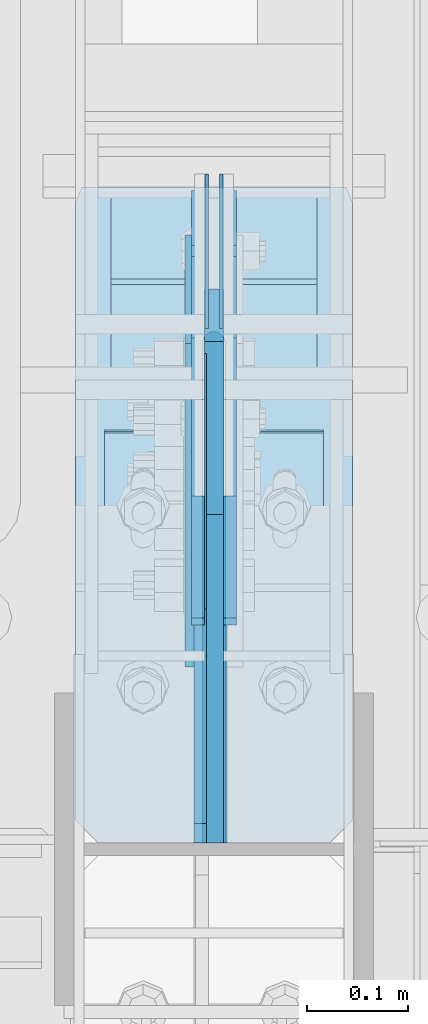
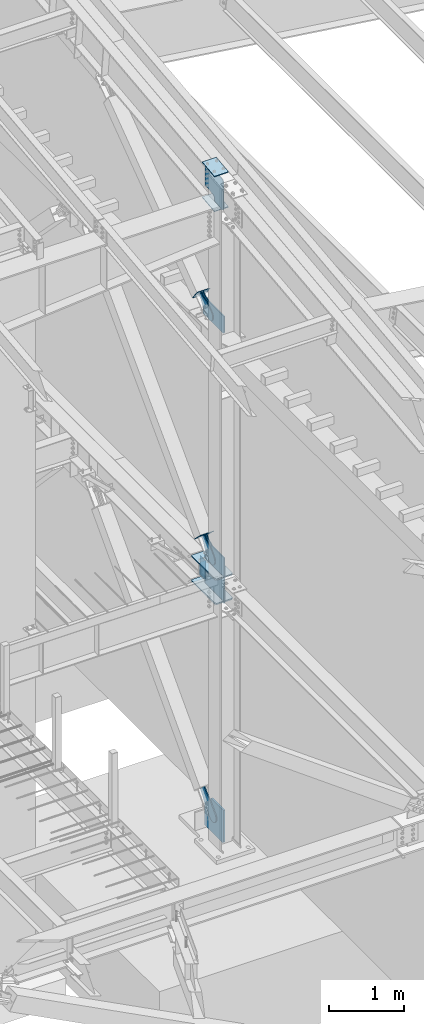
# One storey, part 1011 of 1179: 17 plates, 9 elements without a shape of their own.
"""IFC2X3 building model written with IfcOpenShell, lengths in millimetres."""

from ifc_helpers import new_model, si_unit, frame, origin_with_axes, place, context, subcontext, project, spatial, faceted_brep, material, type_object, element, aggregate, save


model = new_model("IFC2X3")

# Units and contexts
model_context = context("Model", 3, precision=1e-05, world=origin_with_axes())
body_context = subcontext(model_context, "Body", "Model", "MODEL_VIEW")
ifc_project = project(units=[si_unit("LENGTHUNIT", "METRE", prefix="MILLI"), si_unit("AREAUNIT", "SQUARE_METRE"), si_unit("VOLUMEUNIT", "CUBIC_METRE"), si_unit("MASSUNIT", "GRAM", prefix="KILO"), si_unit("TIMEUNIT", "SECOND"), si_unit("PLANEANGLEUNIT", "RADIAN"), si_unit("SOLIDANGLEUNIT", "STERADIAN"), si_unit("THERMODYNAMICTEMPERATUREUNIT", "DEGREE_CELSIUS"), si_unit("LUMINOUSINTENSITYUNIT", "LUMEN")], contexts=[model_context])

# Site, building, storey
site_placement = place(None, origin_with_axes())
site = spatial("IfcSite", under=ifc_project, at=site_placement, CompositionType="ELEMENT")
building_placement = place(site_placement, origin_with_axes())
building = spatial("IfcBuilding", under=site, at=building_placement, Name="Undefined", CompositionType="ELEMENT")
storey_placement = place(building_placement, origin_with_axes())
storey = spatial("IfcBuildingStorey", under=building, at=storey_placement, Name="Undefined", CompositionType="ELEMENT", Elevation=0.0)

# Assembly, plates
assembly_1_placement = place(storey_placement, origin_with_axes())
assembly_1 = element("IfcElementAssembly", 1, at=assembly_1_placement, inside=storey, Name="COLUMN", AssemblyPlace="NOTDEFINED", PredefinedType="RIGID_FRAME")
ifc_material_1 = material(Name="STEEL/A572-GR.50")
plate_type_1 = type_object("IfcPlateType", PredefinedType="NOTDEFINED")
plate_1_placement = place(assembly_1_placement, frame((24171.275012207, 12133.5984303229, 3694.1125), z_axis=(0.0, -1.0, 0.0), x_axis=(1.0, 0.0, 0.0)))
plate_1 = element("IfcPlate", 2, at=plate_1_placement, type_object=plate_type_1, material=ifc_material_1, Name="PLATE", context=body_context, shape_type="Brep", body=[
    faceted_brep([(125.412487792968, -11.1125000000002, 646.448430322878), (125.412487792968, -11.1125000000002, 153.987500190735), (125.412487792968, 11.1125000000002, 153.987500190735), (125.412487792968, 11.1125000000002, 646.448430322878), (126.258376502454, -11.1125000000002, 149.734930475586), (126.258376502454, 11.1125000000002, 149.734930475586), (128.667263742896, -11.1125000000002, 146.12977594993), (128.667263742896, 11.1125000000002, 146.12977594993), (132.272418268556, -11.1125000000002, 143.720888709488), (132.272418268556, 11.1125000000002, 143.720888709488), (136.524987602239, -11.1125000000002, 142.875), (136.524987602239, 11.1125000000002, 142.875), (140.777557317386, -11.1125000000002, 143.720888709488), (140.777557317386, 11.1125000000002, 143.720888709488), (144.382711843045, -11.1125000000002, 146.12977594993), (144.382711843045, 11.1125000000002, 146.12977594993), (146.791599083488, -11.1125000000002, 149.734930475586), (146.791599083488, 11.1125000000002, 149.734930475586), (147.637487792974, -11.1125000000002, 153.987500190735), (147.637487792974, 11.1125000000002, 153.987500190735), (147.637487792974, -11.1125000000002, 646.448430322878), (147.637487792974, 11.1125000000002, 646.448430322878), (0.0, -11.1125000000002, 624.223429941409), (22.2250003814697, -11.1125000000002, 646.448430322878), (22.2250003814697, 11.1125000000002, 646.448430322878), (0.0, 11.1125000000002, 624.223429941409), (0.0, -11.1125000000002, 15.875), (0.0, 11.1125000000002, 15.875), (6.34999990463257, -11.1125000000002, 0.0), (6.34999990463257, 11.1125000000002, 0.0), (266.699987888336, -11.1125000000002, 0.0), (266.699987888336, 11.1125000000002, 0.0), (273.049987792969, -11.1125000000002, 15.875), (273.049987792969, 11.1125000000002, 15.875), (273.049987792969, -11.1125000000002, 624.223429941409), (273.049987792969, 11.1125000000002, 624.223429941409), (250.824987411499, -11.1125000000002, 646.448430322878), (250.824987411499, 11.1125000000002, 646.448430322878)], [[[0, 1, 2, 3]], [[4, 5, 2, 1]], [[6, 7, 5, 4]], [[8, 9, 7, 6]], [[10, 11, 9, 8]], [[12, 13, 11, 10]], [[14, 15, 13, 12]], [[16, 17, 15, 14]], [[18, 19, 17, 16]], [[20, 21, 19, 18]], [[22, 23, 24, 25]], [[26, 22, 25, 27]], [[28, 26, 27, 29]], [[30, 28, 29, 31]], [[32, 30, 31, 33]], [[34, 32, 33, 35]], [[36, 34, 35, 37]], [[16, 14, 12, 10, 8, 6, 4, 1, 0, 23, 22, 26, 28, 30, 32, 34, 36, 20, 18]], [[24, 23, 0, 3]], [[37, 35, 33, 31, 29, 27, 25, 24, 3, 2, 5, 7, 9, 11, 13, 15, 17, 19, 21]], [[36, 37, 21, 20]]]),
])
plate_2_placement = place(assembly_1_placement, frame((24171.275012207, 12133.5984303229, 4090.9875), z_axis=(0.0, -1.0, 0.0), x_axis=(1.0, 0.0, 0.0)))
plate_2 = element("IfcPlate", 3, at=plate_2_placement, type_object=plate_type_1, material=ifc_material_1, Name="PLATE", context=body_context, shape_type="Brep", body=[
    faceted_brep([(125.412487792968, -11.1125000000002, 646.448430322878), (125.412487792968, -11.1125000000002, 153.987500190735), (125.412487792968, 11.1125000000002, 153.987500190735), (125.412487792968, 11.1125000000002, 646.448430322878), (126.258376502454, -11.1125000000002, 149.734930475586), (126.258376502454, 11.1125000000002, 149.734930475586), (128.667263742896, -11.1125000000002, 146.12977594993), (128.667263742896, 11.1125000000002, 146.12977594993), (132.272418268556, -11.1125000000002, 143.720888709488), (132.272418268556, 11.1125000000002, 143.720888709488), (136.524987602239, -11.1125000000002, 142.875), (136.524987602239, 11.1125000000002, 142.875), (140.777557317386, -11.1125000000002, 143.720888709488), (140.777557317386, 11.1125000000002, 143.720888709488), (144.382711843045, -11.1125000000002, 146.12977594993), (144.382711843045, 11.1125000000002, 146.12977594993), (146.791599083488, -11.1125000000002, 149.734930475586), (146.791599083488, 11.1125000000002, 149.734930475586), (147.637487792974, -11.1125000000002, 153.987500190735), (147.637487792974, 11.1125000000002, 153.987500190735), (147.637487792974, -11.1125000000002, 646.448430322878), (147.637487792974, 11.1125000000002, 646.448430322878), (0.0, -11.1125000000002, 624.223429941409), (22.2250003814697, -11.1125000000002, 646.448430322878), (22.2250003814697, 11.1125000000002, 646.448430322878), (0.0, 11.1125000000002, 624.223429941409), (0.0, -11.1125000000002, 15.875), (0.0, 11.1125000000002, 15.875), (6.34999990463257, -11.1125000000002, 0.0), (6.34999990463257, 11.1125000000002, 0.0), (266.699987888336, -11.1125000000002, 0.0), (266.699987888336, 11.1125000000002, 0.0), (273.049987792969, -11.1125000000002, 15.875), (273.049987792969, 11.1125000000002, 15.875), (273.049987792969, -11.1125000000002, 624.223429941409), (273.049987792969, 11.1125000000002, 624.223429941409), (250.824987411499, -11.1125000000002, 646.448430322878), (250.824987411499, 11.1125000000002, 646.448430322878)], [[[0, 1, 2, 3]], [[4, 5, 2, 1]], [[6, 7, 5, 4]], [[8, 9, 7, 6]], [[10, 11, 9, 8]], [[12, 13, 11, 10]], [[14, 15, 13, 12]], [[16, 17, 15, 14]], [[18, 19, 17, 16]], [[20, 21, 19, 18]], [[22, 23, 24, 25]], [[26, 22, 25, 27]], [[28, 26, 27, 29]], [[30, 28, 29, 31]], [[32, 30, 31, 33]], [[34, 32, 33, 35]], [[36, 34, 35, 37]], [[16, 14, 12, 10, 8, 6, 4, 1, 0, 23, 22, 26, 28, 30, 32, 34, 36, 20, 18]], [[24, 23, 0, 3]], [[37, 35, 33, 31, 29, 27, 25, 24, 3, 2, 5, 7, 9, 11, 13, 15, 17, 19, 21]], [[36, 37, 21, 20]]]),
])

# Assembly, plate
assembly_2_placement = place(storey_placement, origin_with_axes())
assembly_2 = element("IfcElementAssembly", 4, at=assembly_2_placement, inside=storey, AssemblyPlace="NOTDEFINED", PredefinedType="RIGID_FRAME")
ifc_material_2 = material(Name="STEEL/A36")
plate_type_2 = type_object("IfcPlateType", PredefinedType="NOTDEFINED")
plate_3_placement = place(assembly_2_placement, frame((24291.925, 12073.4864281147, 8239.6757127596), z_axis=(0.0, -0.591857899923163, 0.806042322895357), x_axis=(0.0, 0.806042322895357, 0.591857899923163)))
plate_3 = element("IfcPlate", 5, at=plate_3_placement, type_object=plate_type_2, material=ifc_material_2, context=body_context, shape_type="Brep", body=[
    faceted_brep([(0.0, -6.34999999999854, 0.0), (-101.600000000211, -6.34999999999854, -44.6881937825565), (-101.600000000211, 6.34999999999854, -44.6881937825565), (0.0, 6.34999999999854, 0.0), (-246.684985848258, -6.34999999999854, -44.6881937827675), (-246.684985848258, 6.34999999999854, -44.6881937827675), (-281.313054102191, -6.34999999999854, -37.800242748639), (-281.313054102191, 6.34999999999854, -37.800242748639), (-310.669312868691, -6.34999999999854, -18.1850177516608), (-310.669312868691, 6.34999999999854, -18.1850177516608), (-330.284537865713, -6.34999999999854, 11.1712410148393), (-330.284537865713, 6.34999999999854, 11.1712410148393), (-337.172488899912, -6.34999999999854, 45.7993031647638), (-337.172488899912, 6.34999999999854, 45.7993031647638), (-330.284537865768, -6.34999999999854, 80.4273714187839), (-330.284537865768, 6.34999999999854, 80.4273714187839), (-310.669312868773, -6.34999999999854, 109.783630185371), (-310.669312868773, 6.34999999999854, 109.783630185371), (-281.313054102271, -6.34999999999854, 129.398855182466), (-281.313054102271, 6.34999999999854, 129.398855182466), (-246.684988899762, -6.34999999999854, 136.286806216707), (-246.684988899762, 6.34999999999854, 136.286806216707), (-101.600000000377, -6.34999999999854, 136.286806216911), (-101.600000000377, 6.34999999999854, 136.286806216911), (-8.18545231595635e-11, -6.34999999999854, 91.5986124346418), (-8.18545231595635e-11, 6.34999999999854, 91.5986124346418), (69.8500000000859, -6.35000000000002, 91.598612434588), (69.8500000000859, 6.35000000000002, 91.598612434588), (69.849999425729, -6.34999999999854, 0.0), (69.849999425729, 6.34999999999854, 0.0)], [[[0, 1, 2, 3]], [[1, 4, 5, 2]], [[4, 6, 7, 5]], [[6, 8, 9, 7]], [[8, 10, 11, 9]], [[10, 12, 13, 11]], [[12, 14, 15, 13]], [[14, 16, 17, 15]], [[16, 18, 19, 17]], [[18, 20, 21, 19]], [[20, 22, 23, 21]], [[22, 24, 25, 23]], [[24, 26, 27, 25]], [[26, 28, 29, 27]], [[28, 0, 3, 29]], [[5, 7, 9, 11, 13, 15, 17, 19, 21, 23, 25, 27, 29, 3, 2]], [[28, 26, 24, 22, 20, 18, 16, 14, 12, 10, 8, 6, 4, 1, 0]]]),
])
aggregate(assembly_2, [plate_3])

assembly_3_placement = place(storey_placement, origin_with_axes())
assembly_3 = element("IfcElementAssembly", 6, at=assembly_3_placement, inside=storey, AssemblyPlace="NOTDEFINED", PredefinedType="RIGID_FRAME")
plate_4_placement = place(assembly_3_placement, frame((24323.675, 12073.4864281147, 8239.6757127596), z_axis=(0.0, -0.591857899923163, 0.806042322895357), x_axis=(0.0, 0.806042322895357, 0.591857899923163)))
plate_4 = element("IfcPlate", 7, at=plate_4_placement, type_object=plate_type_2, material=ifc_material_2, context=body_context, shape_type="Brep", body=[
    faceted_brep([(0.0, -6.34999999999854, 0.0), (-101.600000000211, -6.34999999999854, -44.6881937825565), (-101.600000000211, 6.34999999999854, -44.6881937825565), (0.0, 6.34999999999854, 0.0), (-246.684985848258, -6.34999999999854, -44.6881937827675), (-246.684985848258, 6.34999999999854, -44.6881937827675), (-281.313054102191, -6.34999999999854, -37.800242748639), (-281.313054102191, 6.34999999999854, -37.800242748639), (-310.669312868691, -6.34999999999854, -18.1850177516608), (-310.669312868691, 6.34999999999854, -18.1850177516608), (-330.284537865713, -6.34999999999854, 11.1712410148393), (-330.284537865713, 6.34999999999854, 11.1712410148393), (-337.172488899912, -6.34999999999854, 45.7993031647638), (-337.172488899912, 6.34999999999854, 45.7993031647638), (-330.284537865768, -6.34999999999854, 80.4273714187839), (-330.284537865768, 6.34999999999854, 80.4273714187839), (-310.669312868773, -6.34999999999854, 109.783630185371), (-310.669312868773, 6.34999999999854, 109.783630185371), (-281.313054102271, -6.34999999999854, 129.398855182466), (-281.313054102271, 6.34999999999854, 129.398855182466), (-246.684988899762, -6.34999999999854, 136.286806216707), (-246.684988899762, 6.34999999999854, 136.286806216707), (-101.600000000377, -6.34999999999854, 136.286806216911), (-101.600000000377, 6.34999999999854, 136.286806216911), (-8.18545231595635e-11, -6.34999999999854, 91.5986124346418), (-8.18545231595635e-11, 6.34999999999854, 91.5986124346418), (69.8500000000859, -6.35000000000002, 91.598612434588), (69.8500000000859, 6.35000000000002, 91.598612434588), (69.849999425729, -6.34999999999854, 0.0), (69.849999425729, 6.34999999999854, 0.0)], [[[0, 1, 2, 3]], [[1, 4, 5, 2]], [[4, 6, 7, 5]], [[6, 8, 9, 7]], [[8, 10, 11, 9]], [[10, 12, 13, 11]], [[12, 14, 15, 13]], [[14, 16, 17, 15]], [[16, 18, 19, 17]], [[18, 20, 21, 19]], [[20, 22, 23, 21]], [[22, 24, 25, 23]], [[24, 26, 27, 25]], [[26, 28, 29, 27]], [[28, 0, 3, 29]], [[5, 7, 9, 11, 13, 15, 17, 19, 21, 23, 25, 27, 29, 3, 2]], [[28, 26, 24, 22, 20, 18, 16, 14, 12, 10, 8, 6, 4, 1, 0]]]),
])
aggregate(assembly_3, [plate_4])

assembly_4_placement = place(storey_placement, origin_with_axes())
assembly_4 = element("IfcElementAssembly", 8, at=assembly_4_placement, inside=storey, Name="Plate", AssemblyPlace="NOTDEFINED", PredefinedType="RIGID_FRAME")
plate_type_3 = type_object("IfcPlateType", PredefinedType="NOTDEFINED")
plate_5_placement = place(assembly_4_placement, frame((24409.4, 12160.2553814311, 8234.1601174028), z_axis=(0.0, -0.591857899923163, 0.806042322895357), x_axis=(-1.0, 0.0, 0.0)))
plate_5 = element("IfcPlate", 9, at=plate_5_placement, type_object=plate_type_3, material=ifc_material_2, Name="Plate", context=body_context, shape_type="Brep", body=[
    faceted_brep([(0.0, -3.17500000000109, 0.0), (0.0, -3.17500000000291, 203.200000000368), (0.0, 3.17499999998836, 203.200000000361), (0.0, 3.17500000000109, 7.27595761418343e-12), (203.199999999997, -3.17500000000291, 203.200000000368), (203.199999999997, 3.17499999998836, 203.200000000361), (203.199999999997, -3.17499999999927, 3.63797880709171e-12), (203.199999999997, 3.17499999999382, -3.63797880709171e-12)], [[[0, 1, 2, 3]], [[1, 4, 5, 2]], [[4, 6, 7, 5]], [[6, 0, 3, 7]], [[5, 7, 3, 2]], [[6, 4, 1, 0]]]),
])
aggregate(assembly_4, [plate_5])

assembly_5_placement = place(storey_placement, origin_with_axes())
assembly_5 = element("IfcElementAssembly", 10, at=assembly_5_placement, inside=storey, Name="Plate", AssemblyPlace="NOTDEFINED", PredefinedType="RIGID_FRAME")
plate_6_placement = place(assembly_5_placement, frame((24409.4, 12095.1065777736, 4376.5010434323), z_axis=(0.0, -0.715642339037758, 0.698466923036852), x_axis=(-1.0, 0.0, 0.0)))
plate_6 = element("IfcPlate", 11, at=plate_6_placement, type_object=plate_type_3, material=ifc_material_2, Name="Plate", context=body_context, shape_type="Brep", body=[
    faceted_brep([(0.0, -3.17500000000109, 0.0), (0.0, -3.17500000000291, 203.200000000368), (0.0, 3.17499999998836, 203.200000000361), (0.0, 3.17500000000109, 7.27595761418343e-12), (203.199999999997, -3.17500000000291, 203.200000000368), (203.199999999997, 3.17499999998836, 203.200000000361), (203.199999999997, -3.17499999999927, 3.63797880709171e-12), (203.199999999997, 3.17499999999382, -3.63797880709171e-12)], [[[0, 1, 2, 3]], [[1, 4, 5, 2]], [[4, 6, 7, 5]], [[6, 0, 3, 7]], [[5, 7, 3, 2]], [[6, 4, 1, 0]]]),
])
aggregate(assembly_5, [plate_6])

# Assembly, plates
assembly_6_placement = place(storey_placement, origin_with_axes())
assembly_6 = element("IfcElementAssembly", 12, at=assembly_6_placement, inside=storey, Name="BEAM", AssemblyPlace="NOTDEFINED", PredefinedType="RIGID_FRAME")
plate_type_4 = type_object("IfcPlateType", PredefinedType="NOTDEFINED")
plate_7_placement = place(assembly_6_placement, frame((24300.65625, 12146.2984333746, 4044.95), z_axis=(0.0, 0.0, -1.0), x_axis=(0.0, -1.0, 0.0)))
plate_7 = element("IfcPlate", 13, at=plate_7_placement, type_object=plate_type_4, material=ifc_material_1, Name="PLATE", context=body_context, shape_type="Brep", body=[
    faceted_brep([(3.63797880709171e-12, -1.58750000000055, 1.81898940354586e-12), (-2.18278728425503e-11, -1.58750000000146, 304.8), (-2.18278728425503e-11, 1.58750000000146, 304.8), (-3.63797880709171e-12, 1.58750000000055, 0.0), (152.399999999994, -1.58750000000146, 304.8), (152.399999999994, 1.58750000000146, 304.8), (152.399999999994, -1.58750000000146, 0.0), (152.399999999994, 1.58750000000146, 0.0)], [[[0, 1, 2, 3]], [[1, 4, 5, 2]], [[4, 6, 7, 5]], [[6, 0, 3, 7]], [[5, 7, 3, 2]], [[6, 4, 1, 0]]]),
])
plate_8_placement = place(assembly_6_placement, frame((24314.94375, 12146.2984333746, 4044.95), z_axis=(0.0, 0.0, -1.0), x_axis=(0.0, -1.0, 0.0)))
plate_8 = element("IfcPlate", 14, at=plate_8_placement, type_object=plate_type_4, material=ifc_material_1, Name="PLATE", context=body_context, shape_type="Brep", body=[
    faceted_brep([(3.63797880709171e-12, -1.58750000000055, 1.81898940354586e-12), (-2.18278728425503e-11, -1.58750000000146, 304.8), (-2.18278728425503e-11, 1.58750000000146, 304.8), (-3.63797880709171e-12, 1.58750000000055, 0.0), (152.399999999994, -1.58750000000146, 304.8), (152.399999999994, 1.58750000000146, 304.8), (152.399999999994, -1.58750000000146, 0.0), (152.399999999994, 1.58750000000146, 0.0)], [[[0, 1, 2, 3]], [[1, 4, 5, 2]], [[4, 6, 7, 5]], [[6, 0, 3, 7]], [[5, 7, 3, 2]], [[6, 4, 1, 0]]]),
])
aggregate(assembly_6, [plate_7, plate_8])

# Plate
plate_type_5 = type_object("IfcPlateType", PredefinedType="NOTDEFINED")
plate_9_placement = place(assembly_1_placement, frame((24199.850003078, 11891.8732407573, 10597.0161433958), z_axis=(1.0, 0.0, 0.0), x_axis=(0.0, -0.993676146336441, -0.112284087038017)))
plate_9 = element("IfcPlate", 15, at=plate_9_placement, type_object=plate_type_5, material=ifc_material_1, Name="PLATE", context=body_context, shape_type="Brep", body=[
    faceted_brep([(0.0, -6.34999999999854, 0.0), (0.0, -6.350000000004, 215.899993896484), (0.0, 6.35000000000582, 215.899993896484), (0.0, 6.34999999999854, 0.0), (330.200000001782, -6.34999999994034, 215.899993896483), (330.200000001782, 6.35000000006767, 215.899993896483), (330.200000001782, -6.34999999994034, -1.47792889038101e-12), (330.200000001782, 6.35000000006767, -1.47792889038101e-12)], [[[0, 1, 2, 3]], [[1, 4, 5, 2]], [[4, 6, 7, 5]], [[6, 0, 3, 7]], [[5, 7, 3, 2]], [[6, 4, 1, 0]]]),
])

plate_10_placement = place(assembly_1_placement, frame((24199.8500030614, 11893.2992487651, 10031.6461173839), z_axis=(1.0, 0.0, 0.0), x_axis=(0.0, -0.993676146336441, -0.112284087038017)))
plate_10 = element("IfcPlate", 16, at=plate_10_placement, type_object=plate_type_5, material=ifc_material_1, Name="PLATE", context=body_context, shape_type="Brep", body=[
    faceted_brep([(0.0, -6.34999999999854, 0.0), (0.0, -6.350000000004, 215.899993896484), (0.0, 6.35000000000582, 215.899993896484), (0.0, 6.34999999999854, 0.0), (330.200000001782, -6.34999999994034, 215.899993896483), (330.200000001782, 6.35000000006767, 215.899993896483), (330.200000001782, -6.34999999994034, -1.47792889038101e-12), (330.200000001782, 6.35000000006767, -1.47792889038101e-12)], [[[0, 1, 2, 3]], [[1, 4, 5, 2]], [[4, 6, 7, 5]], [[6, 0, 3, 7]], [[5, 7, 3, 2]], [[6, 4, 1, 0]]]),
])

plate_type_6 = type_object("IfcPlateType", PredefinedType="NOTDEFINED")
plate_11_placement = place(assembly_1_placement, frame((24294.30625, 11487.15, 10039.8278383638), z_axis=(0.0, 0.663574933899741, 0.748109822886957), x_axis=(0.0, 0.748109822886957, -0.663574933899741)))
plate_11 = element("IfcPlate", 17, at=plate_11_placement, type_object=plate_type_6, material=ifc_material_1, Name="PLATE", context=body_context, shape_type="Brep", body=[
    faceted_brep([(0.0, 6.34999999999854, 0.0), (0.0, -6.34999999999854, 0.0), (-303.434077016447, -6.35000000000002, 342.089767131616), (-303.434077016447, 6.35000000000002, 342.089767131616), (25.4641550948563, -6.35000000000002, 0.0), (25.4641550948563, 6.35000000000002, 0.0), (167.045917247172, -6.35000000000002, 157.353263970723), (167.045917247172, 6.35000000000002, 157.353263970723), (131.563526715495, -6.35000000000002, 197.355899250204), (131.563526715495, 6.35000000000002, 197.355899250204), (126.802866418006, -6.35000000000002, 205.238730036501), (126.802866418006, 6.35000000000002, 205.238730036501), (125.165683086001, -6.35000000000002, 214.300878700633), (125.165683086001, 6.35000000000002, 214.300878700633), (126.867175912115, -6.35000000000002, 223.351173161929), (126.867175912115, 6.35000000000002, 223.351173161929), (131.683692556814, -6.35000000000002, 231.199999512715), (131.683692556814, 6.35000000000002, 231.199999512715), (286.794657668127, -6.35000000000002, 403.589566389341), (286.794657668127, 6.35000000000002, 403.589566389341), (23.8827060644498, -6.35000000000002, 699.99493122035), (23.8827060644498, 6.35000000000002, 699.99493122035), (-127.388721232707, -6.35000000000002, 531.872607863961), (-127.388721232707, 6.35000000000002, 531.872607863961), (-134.060951024564, -6.35000000000002, 526.588932486246), (-134.060951024564, 6.35000000000002, 526.588932486246), (-142.104023886786, -6.35000000000002, 523.805974558898), (-142.104023886786, 6.35000000000002, 523.805974558898), (-150.614897093323, -6.35000000000002, 523.836193008534), (-150.614897093323, 6.35000000000002, 523.836193008534), (-158.638005243585, -6.35000000000002, 526.676195033468), (-158.638005243585, 6.35000000000002, 526.676195033468), (-161.049667201236, -6.34999999999854, 528.6139899764), (-303.332301606772, -6.34999999999854, 370.501832962465), (-303.332301606772, 6.34999999999854, 370.501832962465), (-161.049667201236, 6.34999999999854, 528.6139899764)], [[[0, 1, 2, 3]], [[4, 1, 0, 5]], [[6, 4, 5, 7]], [[8, 6, 7, 9]], [[10, 8, 9, 11]], [[12, 10, 11, 13]], [[14, 12, 13, 15]], [[16, 14, 15, 17]], [[18, 16, 17, 19]], [[20, 18, 19, 21]], [[22, 20, 21, 23]], [[24, 22, 23, 25]], [[26, 24, 25, 27]], [[28, 26, 27, 29]], [[30, 28, 29, 31]], [[2, 1, 4, 6, 8, 10, 12, 14, 16, 18, 20, 22, 24, 26, 28, 30, 32, 33]], [[3, 2, 33, 34]], [[31, 29, 27, 25, 23, 21, 19, 17, 15, 13, 11, 9, 7, 5, 0, 3, 34, 35]], [[30, 31, 35, 32]], [[34, 33, 32, 35]]]),
])

# Assembly, plate
assembly_7_placement = place(storey_placement, origin_with_axes())
assembly_7 = element("IfcElementAssembly", 18, at=assembly_7_placement, inside=storey, AssemblyPlace="NOTDEFINED", PredefinedType="RIGID_FRAME")
plate_type_7 = type_object("IfcPlateType", PredefinedType="NOTDEFINED")
plate_12_placement = place(assembly_7_placement, frame((24291.925, 12007.0986472553, 4351.48244043511), z_axis=(0.0, -0.715642339037758, 0.698466923036852), x_axis=(0.0, 0.698466923036852, 0.715642339037758)))
plate_12 = element("IfcPlate", 19, at=plate_12_placement, type_object=plate_type_7, material=ifc_material_2, context=body_context, shape_type="Brep", body=[
    faceted_brep([(0.0, -6.34999999999854, 0.0), (-101.599999999963, -6.34999999999854, -37.5700345970108), (-101.599999999963, 6.34999999999854, -37.5700345970108), (0.0, 6.34999999999854, 0.0), (-245.369242323884, -6.34999999999854, -37.5700345970945), (-245.369242323884, 6.34999999999854, -37.5700345970945), (-281.212328723803, -6.34999999999854, -30.4404014271258), (-281.212328723803, 6.34999999999854, -30.4404014271258), (-311.598630137756, -6.34999999999854, -10.1369239370142), (-311.598630137756, 6.34999999999854, -10.1369239370142), (-331.902107627997, -6.34999999999854, 20.24937747687), (-331.902107627997, 6.34999999999854, 20.24937747687), (-339.031740798124, -6.34999999999854, 56.0924669287269), (-339.031740798124, 6.34999999999854, 56.0924669287269), (-331.902107628228, -6.34999999999854, 91.9355533287926), (-331.902107628228, 6.34999999999854, 91.9355533287926), (-311.598630138099, -6.34999999999854, 122.321854742866), (-311.598630138099, 6.34999999999854, 122.321854742866), (-281.212328724136, -6.34999999999854, 142.625332233139), (-281.212328724136, 6.34999999999854, 142.625332233139), (-245.36924079839, -6.34999999999854, 149.754965403199), (-245.36924079839, 6.34999999999854, 149.754965403199), (-101.600000000685, -6.34999999999854, 149.75496540329), (-101.600000000685, 6.34999999999854, 149.75496540329), (-4.35647962149233e-10, -6.34999999999854, 112.184930806416), (-4.35647962149233e-10, 6.34999999999854, 112.184930806416), (82.5499999996491, -6.34999999999854, 112.184930806461), (82.5499999996491, 6.34999999999854, 112.184930806461), (82.550000000203, -6.34999999999854, 1.2732925824821e-10), (82.550000000203, 6.34999999999854, 1.2732925824821e-10)], [[[0, 1, 2, 3]], [[1, 4, 5, 2]], [[4, 6, 7, 5]], [[6, 8, 9, 7]], [[8, 10, 11, 9]], [[10, 12, 13, 11]], [[12, 14, 15, 13]], [[14, 16, 17, 15]], [[16, 18, 19, 17]], [[18, 20, 21, 19]], [[20, 22, 23, 21]], [[22, 24, 25, 23]], [[24, 26, 27, 25]], [[26, 28, 29, 27]], [[28, 0, 3, 29]], [[5, 7, 9, 11, 13, 15, 17, 19, 21, 23, 25, 27, 29, 3, 2]], [[28, 26, 24, 22, 20, 18, 16, 14, 12, 10, 8, 6, 4, 1, 0]]]),
])
aggregate(assembly_7, [plate_12])

assembly_8_placement = place(storey_placement, origin_with_axes())
assembly_8 = element("IfcElementAssembly", 20, at=assembly_8_placement, inside=storey, AssemblyPlace="NOTDEFINED", PredefinedType="RIGID_FRAME")
plate_13_placement = place(assembly_8_placement, frame((24323.675, 12007.0986472553, 4351.48244043511), z_axis=(0.0, -0.715642339037758, 0.698466923036852), x_axis=(0.0, 0.698466923036852, 0.715642339037758)))
plate_13 = element("IfcPlate", 21, at=plate_13_placement, type_object=plate_type_7, material=ifc_material_2, context=body_context, shape_type="Brep", body=[
    faceted_brep([(0.0, -6.34999999999854, 0.0), (-101.599999999963, -6.34999999999854, -37.5700345970108), (-101.599999999963, 6.34999999999854, -37.5700345970108), (0.0, 6.34999999999854, 0.0), (-245.369242323884, -6.34999999999854, -37.5700345970945), (-245.369242323884, 6.34999999999854, -37.5700345970945), (-281.212328723803, -6.34999999999854, -30.4404014271258), (-281.212328723803, 6.34999999999854, -30.4404014271258), (-311.598630137756, -6.34999999999854, -10.1369239370142), (-311.598630137756, 6.34999999999854, -10.1369239370142), (-331.902107627997, -6.34999999999854, 20.24937747687), (-331.902107627997, 6.34999999999854, 20.24937747687), (-339.031740798124, -6.34999999999854, 56.0924669287269), (-339.031740798124, 6.34999999999854, 56.0924669287269), (-331.902107628228, -6.34999999999854, 91.9355533287926), (-331.902107628228, 6.34999999999854, 91.9355533287926), (-311.598630138099, -6.34999999999854, 122.321854742866), (-311.598630138099, 6.34999999999854, 122.321854742866), (-281.212328724136, -6.34999999999854, 142.625332233139), (-281.212328724136, 6.34999999999854, 142.625332233139), (-245.36924079839, -6.34999999999854, 149.754965403199), (-245.36924079839, 6.34999999999854, 149.754965403199), (-101.600000000685, -6.34999999999854, 149.75496540329), (-101.600000000685, 6.34999999999854, 149.75496540329), (-4.35647962149233e-10, -6.34999999999854, 112.184930806416), (-4.35647962149233e-10, 6.34999999999854, 112.184930806416), (82.5499999996491, -6.34999999999854, 112.184930806461), (82.5499999996491, 6.34999999999854, 112.184930806461), (82.550000000203, -6.34999999999854, 1.2732925824821e-10), (82.550000000203, 6.34999999999854, 1.2732925824821e-10)], [[[0, 1, 2, 3]], [[1, 4, 5, 2]], [[4, 6, 7, 5]], [[6, 8, 9, 7]], [[8, 10, 11, 9]], [[10, 12, 13, 11]], [[12, 14, 15, 13]], [[14, 16, 17, 15]], [[16, 18, 19, 17]], [[18, 20, 21, 19]], [[20, 22, 23, 21]], [[22, 24, 25, 23]], [[24, 26, 27, 25]], [[26, 28, 29, 27]], [[28, 0, 3, 29]], [[5, 7, 9, 11, 13, 15, 17, 19, 21, 23, 25, 27, 29, 3, 2]], [[28, 26, 24, 22, 20, 18, 16, 14, 12, 10, 8, 6, 4, 1, 0]]]),
])
aggregate(assembly_8, [plate_13])

# Plate
plate_type_8 = type_object("IfcPlateType", PredefinedType="NOTDEFINED")
plate_14_placement = place(assembly_1_placement, frame((24307.8, 11487.15, 8026.4), z_axis=(0.0, 0.0, 1.0), x_axis=(0.0, 1.0, 0.0)))
plate_14 = element("IfcPlate", 22, at=plate_14_placement, type_object=plate_type_8, material=ifc_material_1, Name="PLATE", context=body_context, shape_type="Brep", body=[
    faceted_brep([(0.0, -9.52500000000146, 19.0499992370605), (0.0, -9.52500000000146, 283.469358990927), (0.0, 9.52500000000146, 283.469358990927), (0.0, 9.52500000000146, 19.0499992370605), (408.746914534087, -9.52500000000146, 283.469358990927), (408.746914534087, 9.52500000000146, 283.469358990927), (545.92477928878, -9.52500000000146, 96.6488996018561), (545.92477928878, 9.52500000000146, 96.6488996018561), (545.92477928878, -9.52500000000146, 0.0), (545.92477928878, 9.52500000000146, 0.0), (19.0499992370605, -9.52500000000146, 0.0), (19.0499992370605, 9.52500000000146, 0.0)], [[[0, 1, 2, 3]], [[1, 4, 5, 2]], [[4, 6, 7, 5]], [[6, 8, 9, 7]], [[8, 10, 11, 9]], [[10, 0, 3, 11]], [[5, 7, 9, 11, 3, 2]], [[10, 8, 6, 4, 1, 0]]]),
])

plate_type_9 = type_object("IfcPlateType", PredefinedType="NOTDEFINED")
plate_15_placement = place(assembly_1_placement, frame((24307.8, 11487.15, 3663.95), z_axis=(0.0, 0.0, 1.0), x_axis=(0.0, 1.0, 0.0)))
plate_15 = element("IfcPlate", 23, at=plate_15_placement, type_object=plate_type_9, material=ifc_material_1, Name="PLATE", context=body_context, shape_type="Brep", body=[
    faceted_brep([(0.0, -9.52499999999964, 0.0), (-3.63797880709171e-12, -9.52499999999998, 737.163128918689), (-3.63797880709171e-12, 9.52499999999998, 737.163128918689), (0.0, 9.52499999999964, 0.0), (323.636098339506, -9.52499999999998, 737.163128918689), (323.636098339506, 9.52499999999998, 737.163128918689), (494.048430322873, -9.52499999999998, 570.84069287054), (494.048430322873, 9.52499999999998, 570.84069287054), (494.048430322877, -9.52499999999998, 0.0), (494.048430322877, 9.52499999999998, 0.0)], [[[0, 1, 2, 3]], [[1, 4, 5, 2]], [[4, 6, 7, 5]], [[6, 8, 9, 7]], [[8, 0, 3, 9]], [[5, 7, 9, 3, 2]], [[8, 6, 4, 1, 0]]]),
])

plate_type_10 = type_object("IfcPlateType", PredefinedType="NOTDEFINED")
plate_16_placement = place(assembly_1_placement, frame((24307.8, 11487.15, -215.899999999999), z_axis=(0.0, 0.0, 1.0), x_axis=(0.0, 1.0, 0.0)))
plate_16 = element("IfcPlate", 24, at=plate_16_placement, type_object=plate_type_10, material=ifc_material_1, Name="PLATE", context=body_context, shape_type="Brep", body=[
    faceted_brep([(0.0, -12.7000000000007, 19.0500000000029), (0.0, -12.7, 534.018748335632), (0.0, 12.7, 534.018748335632), (0.0, 12.7000000000007, 19.0500000000029), (331.311918860847, -12.7, 534.018748335632), (331.311918860847, 12.7, 534.018748335632), (506.88311243628, -12.7, 368.487947617164), (506.88311243628, 12.7, 368.487947617164), (506.88311243628, -12.7, 0.0), (506.88311243628, 12.7, 0.0), (19.0499992370605, -12.6999999999971, 0.0), (19.0499992370605, 12.6999999999971, 0.0)], [[[0, 1, 2, 3]], [[1, 4, 5, 2]], [[4, 6, 7, 5]], [[6, 8, 9, 7]], [[8, 10, 11, 9]], [[10, 0, 3, 11]], [[5, 7, 9, 11, 3, 2]], [[10, 8, 6, 4, 1, 0]]]),
])

aggregate(assembly_1, [plate_1, plate_2, plate_9, plate_10, plate_11, plate_14, plate_15, plate_16])

# Assembly, plate
assembly_9_placement = place(storey_placement, origin_with_axes())
assembly_9 = element("IfcElementAssembly", 25, at=assembly_9_placement, inside=storey, AssemblyPlace="NOTDEFINED", PredefinedType="RIGID_FRAME")
plate_type_11 = type_object("IfcPlateType", PredefinedType="NOTDEFINED")
plate_17_placement = place(assembly_9_placement, frame((24287.1625, 12029.3890753335, 258.890005327186), z_axis=(0.0, -0.727605443744034, 0.685995858758671), x_axis=(0.0, 0.685995858758672, 0.727605443744034)))
plate_17 = element("IfcPlate", 26, at=plate_17_placement, type_object=plate_type_11, material=ifc_material_2, context=body_context, shape_type="Brep", body=[
    faceted_brep([(0.0, -7.9375, 0.0), (-101.600000000497, -7.9375, -21.7975798445477), (-101.600000000497, 7.9375, -21.7975798445477), (0.0, 7.9375, 0.0), (-320.921138851689, -7.9375, -21.7975798443877), (-320.921138851689, 7.9375, -21.7975798443877), (-357.371735784433, -7.9375, -14.5471053160727), (-357.371735784433, 7.9375, -14.5471053160727), (-388.273059759649, -7.9375, 6.10049924760824), (-388.273059759649, 7.9375, 6.10049924760824), (-408.920664323319, -7.9375, 37.0018232228431), (-408.920664323319, 7.9375, 37.0018232228431), (-416.171138851623, -7.9375, 73.4524201546446), (-416.171138851623, 7.9375, 73.4524201546446), (-408.920664323337, -7.9375, 109.903017087447), (-408.920664323337, 7.9375, 109.903017087447), (-388.273059759656, -7.9375, 140.804341062707), (-388.273059759656, 7.9375, 140.804341062707), (-357.3717357844, -7.9375, 161.451945626395), (-357.3717357844, 7.9375, 161.451945626395), (-320.921138851201, -7.9375, 168.702420154674), (-320.921138851201, 7.9375, 168.702420154674), (-101.600000000592, -7.9375, 168.702420154521), (-101.600000000592, 7.9375, 168.702420154521), (-8.00355337560177e-11, -7.9375, 146.904840309817), (-8.00355337560177e-11, 7.9375, 146.904840309817), (82.5499999998137, -7.9375, 146.90484031055), (82.5499999998137, 7.9375, 146.90484031055), (82.5500000000975, -7.9375, -6.91215973347425e-11), (82.5500000000975, 7.9375, -6.91215973347425e-11)], [[[0, 1, 2, 3]], [[1, 4, 5, 2]], [[4, 6, 7, 5]], [[6, 8, 9, 7]], [[8, 10, 11, 9]], [[10, 12, 13, 11]], [[12, 14, 15, 13]], [[14, 16, 17, 15]], [[16, 18, 19, 17]], [[18, 20, 21, 19]], [[20, 22, 23, 21]], [[22, 24, 25, 23]], [[24, 26, 27, 25]], [[26, 28, 29, 27]], [[28, 0, 3, 29]], [[5, 7, 9, 11, 13, 15, 17, 19, 21, 23, 25, 27, 29, 3, 2]], [[28, 26, 24, 22, 20, 18, 16, 14, 12, 10, 8, 6, 4, 1, 0]]]),
])
aggregate(assembly_9, [plate_17])

save(model, "model.ifc")
